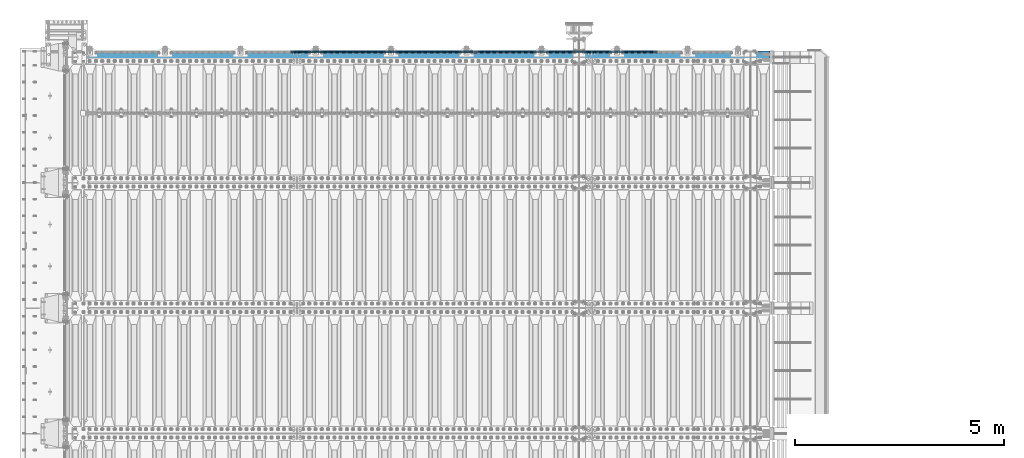
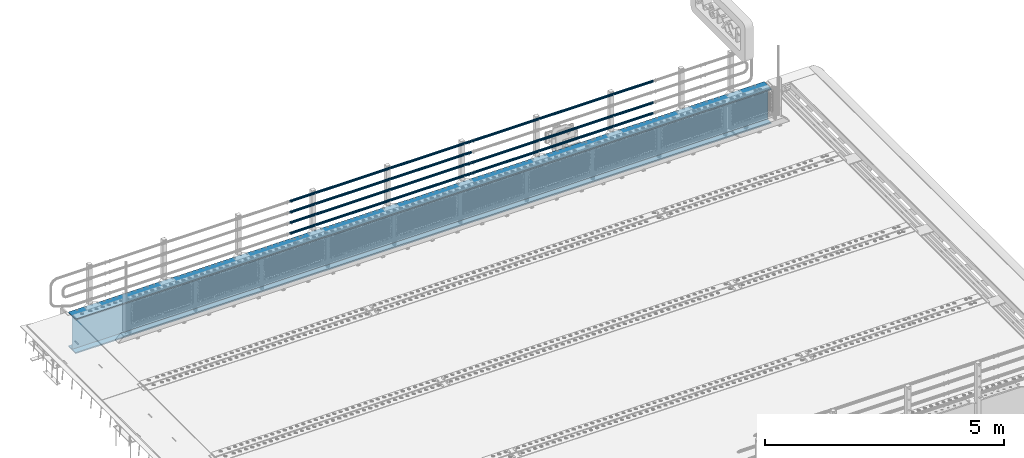
# One storey, part 128 of 257: 8 beams.
"""IFC2X3 building model written with IfcOpenShell, lengths in millimetres."""

from ifc_helpers import new_model, si_unit, frame, origin_with_axes, place, context, subcontext, project, spatial, faceted_brep, material, type_object, element, save


model = new_model("IFC2X3")

# Units and contexts
model_context = context("Model", 3, precision=1e-05, world=origin_with_axes())
body_context = subcontext(model_context, "Body", "Model", "MODEL_VIEW")
ifc_project = project(units=[si_unit("LENGTHUNIT", "METRE", prefix="MILLI"), si_unit("AREAUNIT", "SQUARE_METRE"), si_unit("VOLUMEUNIT", "CUBIC_METRE"), si_unit("MASSUNIT", "GRAM", prefix="KILO"), si_unit("TIMEUNIT", "SECOND"), si_unit("PLANEANGLEUNIT", "RADIAN"), si_unit("SOLIDANGLEUNIT", "STERADIAN"), si_unit("THERMODYNAMICTEMPERATUREUNIT", "DEGREE_CELSIUS"), si_unit("LUMINOUSINTENSITYUNIT", "LUMEN")], contexts=[model_context])

# Site, building, storey
site_placement = place(None, origin_with_axes())
site = spatial("IfcSite", under=ifc_project, at=site_placement, CompositionType="ELEMENT")
building_placement = place(site_placement, origin_with_axes())
building = spatial("IfcBuilding", under=site, at=building_placement, Name="Standard", CompositionType="ELEMENT")
storey_placement = place(building_placement, origin_with_axes())
storey = spatial("IfcBuildingStorey", under=building, at=storey_placement, Name="Undefined", CompositionType="ELEMENT", Elevation=0.0)

# Beams
ifc_material_1 = material()
beam_type_1 = type_object("IfcBeamType", PredefinedType="NOTDEFINED")
beam_1_placement = place(storey_placement, frame((52177.9999999999, 12129.8500000001, 149.849999999725), z_axis=(0.0, 0.0, -1.0), x_axis=(-1.0, 0.0, 0.0)))
element("IfcBeam", 1, at=beam_1_placement, inside=storey, type_object=beam_type_1, material=ifc_material_1, context=body_context, shape_type="Brep", body=[
    faceted_brep([(0.0, -26.5499999999993, 0.0), (0.0, -24.5290015881747, 10.1602451292931), (4384.00249699992, -24.5290015881747, 10.1602451292931), (4384.00249699992, -26.5499999999993, 0.0), (0.0, -18.7736850405036, 18.7736850405028), (4384.00249699992, -18.7736850405036, 18.7736850405028), (0.0, -10.1602451292929, 24.5290015881747), (4384.00249699992, -10.1602451292929, 24.5290015881747), (0.0, 0.0, 26.55), (4384.00249699992, 0.0, 26.55), (0.0, 10.1602451292929, 24.5290015881747), (4384.00249699992, 10.1602451292929, 24.5290015881747), (0.0, 18.7736850405036, 18.7736850405028), (4384.00249699992, 18.7736850405036, 18.7736850405028), (0.0, 24.5290015881747, 10.1602451292931), (4384.00249699992, 24.5290015881747, 10.1602451292931), (0.0, 26.5499999999993, 0.0), (4384.00249699992, 26.5499999999993, 0.0), (0.0, 24.5290015881747, -10.1602451292931), (4384.00249699992, 24.5290015881747, -10.1602451292931), (0.0, 18.7736850405036, -18.7736850405028), (4384.00249699992, 18.7736850405036, -18.7736850405028), (0.0, 10.1602451292929, -24.5290015881747), (4384.00249699992, 10.1602451292929, -24.5290015881747), (0.0, 0.0, -26.55), (4384.00249699992, 0.0, -26.55), (0.0, -10.1602451292929, -24.5290015881747), (4384.00249699992, -10.1602451292929, -24.5290015881747), (0.0, -18.7736850405036, -18.7736850405028), (4384.00249699992, -18.7736850405036, -18.7736850405028), (0.0, -24.5290015881747, -10.1602451292931), (4384.00249699992, -24.5290015881747, -10.1602451292931), (0.0, -30.1499999999996, 0.0), (0.0, -27.8549679052157, -11.5379054858058), (4384.00249699992, -27.8549679052157, -11.5379054858075), (4384.00249699992, -30.1499999999996, 0.0), (0.0, -21.3192694527752, -21.3192694527752), (4384.00249699992, -21.3192694527752, -21.3192694527744), (0.0, -11.5379054858076, -27.8549679052157), (4384.00249699992, -11.5379054858076, -27.8549679052153), (0.0, 0.0, -30.1500000000015), (4384.00249699992, 0.0, -30.15), (0.0, 11.5379054858076, -27.8549679052157), (4384.00249699992, 11.5379054858076, -27.8549679052153), (0.0, 21.3192694527752, -21.3192694527752), (4384.00249699992, 21.3192694527752, -21.3192694527744), (0.0, 27.8549679052157, -11.5379054858058), (4384.00249699992, 27.8549679052157, -11.5379054858074), (0.0, 30.1499999999996, 0.0), (4384.00249699992, 30.1499999999996, 0.0), (0.0, 27.8549679052157, 11.5379054858058), (4384.00249699992, 27.8549679052157, 11.5379054858075), (0.0, 21.3192694527752, 21.3192694527752), (4384.00249699992, 21.3192694527752, 21.3192694527744), (0.0, 11.5379054858076, 27.8549679052157), (4384.00249699992, 11.5379054858076, 27.8549679052153), (0.0, 0.0, 30.1500000000015), (4384.00249699992, 0.0, 30.15), (0.0, -11.5379054858076, 27.8549679052157), (4384.00249699992, -11.5379054858076, 27.8549679052153), (0.0, -21.3192694527752, 21.3192694527752), (4384.00249699992, -21.3192694527752, 21.3192694527744), (0.0, -27.8549679052157, 11.5379054858058), (4384.00249699992, -27.8549679052157, 11.5379054858075)], [[[0, 1, 2, 3]], [[1, 4, 5, 2]], [[4, 6, 7, 5]], [[6, 8, 9, 7]], [[8, 10, 11, 9]], [[10, 12, 13, 11]], [[12, 14, 15, 13]], [[14, 16, 17, 15]], [[16, 18, 19, 17]], [[18, 20, 21, 19]], [[20, 22, 23, 21]], [[22, 24, 25, 23]], [[24, 26, 27, 25]], [[26, 28, 29, 27]], [[28, 30, 31, 29]], [[30, 0, 3, 31]], [[32, 33, 34, 35]], [[33, 36, 37, 34]], [[36, 38, 39, 37]], [[38, 40, 41, 39]], [[40, 42, 43, 41]], [[42, 44, 45, 43]], [[44, 46, 47, 45]], [[46, 48, 49, 47]], [[48, 50, 51, 49]], [[50, 52, 53, 51]], [[52, 54, 55, 53]], [[54, 56, 57, 55]], [[56, 58, 59, 57]], [[58, 60, 61, 59]], [[60, 62, 63, 61]], [[62, 32, 35, 63]], [[37, 39, 41, 43, 45, 47, 49, 51, 53, 55, 57, 59, 61, 63, 35, 34], [5, 7, 9, 11, 13, 15, 17, 19, 21, 23, 25, 27, 29, 31, 3, 2]], [[62, 60, 58, 56, 54, 52, 50, 48, 46, 44, 42, 40, 38, 36, 33, 32], [30, 28, 26, 24, 22, 20, 18, 16, 14, 12, 10, 8, 6, 4, 1, 0]]]),
])
beam_2_placement = place(storey_placement, frame((56571.9999999999, 12129.8500000002, 149.849999999725), z_axis=(0.0, 0.0, -1.0), x_axis=(-1.0, 0.0, 0.0)))
element("IfcBeam", 2, at=beam_2_placement, inside=storey, type_object=beam_type_1, material=ifc_material_1, context=body_context, shape_type="Brep", body=[
    faceted_brep([(0.0, -26.5499999999993, 0.0), (0.0, -24.5290015881747, 10.1602451292931), (4384.0, -24.5290015881747, 10.1602451292931), (4384.0, -26.5499999999993, 0.0), (0.0, -18.7736850405036, 18.7736850405028), (4384.0, -18.7736850405036, 18.7736850405028), (0.0, -10.1602451292929, 24.5290015881747), (4384.0, -10.1602451292929, 24.5290015881747), (0.0, 0.0, 26.55), (4384.0, 0.0, 26.55), (0.0, 10.1602451292929, 24.5290015881747), (4384.0, 10.1602451292929, 24.5290015881747), (0.0, 18.7736850405036, 18.7736850405028), (4384.0, 18.7736850405036, 18.7736850405028), (0.0, 24.5290015881747, 10.1602451292931), (4384.0, 24.5290015881747, 10.1602451292931), (0.0, 26.5499999999993, 0.0), (4384.0, 26.5499999999993, 0.0), (0.0, 24.5290015881747, -10.1602451292931), (4384.0, 24.5290015881747, -10.1602451292931), (0.0, 18.7736850405036, -18.7736850405028), (4384.0, 18.7736850405036, -18.7736850405028), (0.0, 10.1602451292929, -24.5290015881747), (4384.0, 10.1602451292929, -24.5290015881747), (0.0, 0.0, -26.55), (4384.0, 0.0, -26.55), (0.0, -10.1602451292929, -24.5290015881747), (4384.0, -10.1602451292929, -24.5290015881747), (0.0, -18.7736850405036, -18.7736850405028), (4384.0, -18.7736850405036, -18.7736850405028), (0.0, -24.5290015881747, -10.1602451292931), (4384.0, -24.5290015881747, -10.1602451292931), (0.0, -30.1499999999996, 0.0), (0.0, -27.8549679052157, -11.5379054858058), (4384.0, -27.8549679052157, -11.5379054858075), (4384.0, -30.1499999999996, 0.0), (0.0, -21.3192694527752, -21.3192694527752), (4384.0, -21.3192694527752, -21.3192694527744), (0.0, -11.5379054858076, -27.8549679052157), (4384.0, -11.5379054858076, -27.8549679052153), (0.0, 0.0, -30.1500000000015), (4384.0, 0.0, -30.15), (0.0, 11.5379054858076, -27.8549679052157), (4384.0, 11.5379054858076, -27.8549679052153), (0.0, 21.3192694527752, -21.3192694527752), (4384.0, 21.3192694527752, -21.3192694527744), (0.0, 27.8549679052157, -11.5379054858058), (4384.0, 27.8549679052157, -11.5379054858074), (0.0, 30.1499999999996, 0.0), (4384.0, 30.1499999999996, 0.0), (0.0, 27.8549679052157, 11.5379054858058), (4384.0, 27.8549679052157, 11.5379054858075), (0.0, 21.3192694527752, 21.3192694527752), (4384.0, 21.3192694527752, 21.3192694527744), (0.0, 11.5379054858076, 27.8549679052157), (4384.0, 11.5379054858076, 27.8549679052153), (0.0, 0.0, 30.1500000000015), (4384.0, 0.0, 30.15), (0.0, -11.5379054858076, 27.8549679052157), (4384.0, -11.5379054858076, 27.8549679052153), (0.0, -21.3192694527752, 21.3192694527752), (4384.0, -21.3192694527752, 21.3192694527744), (0.0, -27.8549679052157, 11.5379054858058), (4384.0, -27.8549679052157, 11.5379054858075)], [[[0, 1, 2, 3]], [[1, 4, 5, 2]], [[4, 6, 7, 5]], [[6, 8, 9, 7]], [[8, 10, 11, 9]], [[10, 12, 13, 11]], [[12, 14, 15, 13]], [[14, 16, 17, 15]], [[16, 18, 19, 17]], [[18, 20, 21, 19]], [[20, 22, 23, 21]], [[22, 24, 25, 23]], [[24, 26, 27, 25]], [[26, 28, 29, 27]], [[28, 30, 31, 29]], [[30, 0, 3, 31]], [[32, 33, 34, 35]], [[33, 36, 37, 34]], [[36, 38, 39, 37]], [[38, 40, 41, 39]], [[40, 42, 43, 41]], [[42, 44, 45, 43]], [[44, 46, 47, 45]], [[46, 48, 49, 47]], [[48, 50, 51, 49]], [[50, 52, 53, 51]], [[52, 54, 55, 53]], [[54, 56, 57, 55]], [[56, 58, 59, 57]], [[58, 60, 61, 59]], [[60, 62, 63, 61]], [[62, 32, 35, 63]], [[37, 39, 41, 43, 45, 47, 49, 51, 53, 55, 57, 59, 61, 63, 35, 34], [5, 7, 9, 11, 13, 15, 17, 19, 21, 23, 25, 27, 29, 31, 3, 2]], [[62, 60, 58, 56, 54, 52, 50, 48, 46, 44, 42, 40, 38, 36, 33, 32], [30, 28, 26, 24, 22, 20, 18, 16, 14, 12, 10, 8, 6, 4, 1, 0]]]),
])
beam_3_placement = place(storey_placement, frame((52177.9999999999, 12129.8500000001, 420.149999999728), z_axis=(0.0, 0.0, -1.0), x_axis=(-1.0, 0.0, 0.0)))
element("IfcBeam", 3, at=beam_3_placement, inside=storey, type_object=beam_type_1, material=ifc_material_1, context=body_context, shape_type="Brep", body=[
    faceted_brep([(0.0, -26.5499999999993, 0.0), (0.0, -24.5290015881747, 10.1602451292931), (4384.00249699992, -24.5290015881747, 10.1602451292931), (4384.00249699992, -26.5499999999993, 0.0), (0.0, -18.7736850405036, 18.7736850405028), (4384.00249699992, -18.7736850405036, 18.7736850405028), (0.0, -10.1602451292929, 24.5290015881747), (4384.00249699992, -10.1602451292929, 24.5290015881747), (0.0, 0.0, 26.55), (4384.00249699992, 0.0, 26.55), (0.0, 10.1602451292929, 24.5290015881747), (4384.00249699992, 10.1602451292929, 24.5290015881747), (0.0, 18.7736850405036, 18.7736850405028), (4384.00249699992, 18.7736850405036, 18.7736850405028), (0.0, 24.5290015881747, 10.1602451292931), (4384.00249699992, 24.5290015881747, 10.1602451292931), (0.0, 26.5499999999993, 0.0), (4384.00249699992, 26.5499999999993, 0.0), (0.0, 24.5290015881747, -10.1602451292931), (4384.00249699992, 24.5290015881747, -10.1602451292931), (0.0, 18.7736850405036, -18.7736850405028), (4384.00249699992, 18.7736850405036, -18.7736850405028), (0.0, 10.1602451292929, -24.5290015881747), (4384.00249699992, 10.1602451292929, -24.5290015881747), (0.0, 0.0, -26.55), (4384.00249699992, 0.0, -26.55), (0.0, -10.1602451292929, -24.5290015881747), (4384.00249699992, -10.1602451292929, -24.5290015881747), (0.0, -18.7736850405036, -18.7736850405028), (4384.00249699992, -18.7736850405036, -18.7736850405028), (0.0, -24.5290015881747, -10.1602451292931), (4384.00249699992, -24.5290015881747, -10.1602451292931), (0.0, -30.1499999999996, 0.0), (0.0, -27.8549679052157, -11.5379054858058), (4384.00249699992, -27.8549679052157, -11.5379054858075), (4384.00249699992, -30.1499999999996, 0.0), (0.0, -21.3192694527752, -21.3192694527752), (4384.00249699992, -21.3192694527752, -21.3192694527744), (0.0, -11.5379054858076, -27.8549679052157), (4384.00249699992, -11.5379054858076, -27.8549679052153), (0.0, 0.0, -30.1500000000015), (4384.00249699992, 0.0, -30.15), (0.0, 11.5379054858076, -27.8549679052157), (4384.00249699992, 11.5379054858076, -27.8549679052153), (0.0, 21.3192694527752, -21.3192694527752), (4384.00249699992, 21.3192694527752, -21.3192694527744), (0.0, 27.8549679052157, -11.5379054858058), (4384.00249699992, 27.8549679052157, -11.5379054858074), (0.0, 30.1499999999996, 0.0), (4384.00249699992, 30.1499999999996, 0.0), (0.0, 27.8549679052157, 11.5379054858058), (4384.00249699992, 27.8549679052157, 11.5379054858075), (0.0, 21.3192694527752, 21.3192694527752), (4384.00249699992, 21.3192694527752, 21.3192694527744), (0.0, 11.5379054858076, 27.8549679052157), (4384.00249699992, 11.5379054858076, 27.8549679052153), (0.0, 0.0, 30.1500000000015), (4384.00249699992, 0.0, 30.15), (0.0, -11.5379054858076, 27.8549679052157), (4384.00249699992, -11.5379054858076, 27.8549679052153), (0.0, -21.3192694527752, 21.3192694527752), (4384.00249699992, -21.3192694527752, 21.3192694527744), (0.0, -27.8549679052157, 11.5379054858058), (4384.00249699992, -27.8549679052157, 11.5379054858075)], [[[0, 1, 2, 3]], [[1, 4, 5, 2]], [[4, 6, 7, 5]], [[6, 8, 9, 7]], [[8, 10, 11, 9]], [[10, 12, 13, 11]], [[12, 14, 15, 13]], [[14, 16, 17, 15]], [[16, 18, 19, 17]], [[18, 20, 21, 19]], [[20, 22, 23, 21]], [[22, 24, 25, 23]], [[24, 26, 27, 25]], [[26, 28, 29, 27]], [[28, 30, 31, 29]], [[30, 0, 3, 31]], [[32, 33, 34, 35]], [[33, 36, 37, 34]], [[36, 38, 39, 37]], [[38, 40, 41, 39]], [[40, 42, 43, 41]], [[42, 44, 45, 43]], [[44, 46, 47, 45]], [[46, 48, 49, 47]], [[48, 50, 51, 49]], [[50, 52, 53, 51]], [[52, 54, 55, 53]], [[54, 56, 57, 55]], [[56, 58, 59, 57]], [[58, 60, 61, 59]], [[60, 62, 63, 61]], [[62, 32, 35, 63]], [[37, 39, 41, 43, 45, 47, 49, 51, 53, 55, 57, 59, 61, 63, 35, 34], [5, 7, 9, 11, 13, 15, 17, 19, 21, 23, 25, 27, 29, 31, 3, 2]], [[62, 60, 58, 56, 54, 52, 50, 48, 46, 44, 42, 40, 38, 36, 33, 32], [30, 28, 26, 24, 22, 20, 18, 16, 14, 12, 10, 8, 6, 4, 1, 0]]]),
])
beam_4_placement = place(storey_placement, frame((56571.9999999999, 12129.8500000002, 420.149999999728), z_axis=(0.0, 0.0, -1.0), x_axis=(-1.0, 0.0, 0.0)))
element("IfcBeam", 4, at=beam_4_placement, inside=storey, type_object=beam_type_1, material=ifc_material_1, context=body_context, shape_type="Brep", body=[
    faceted_brep([(0.0, -26.5499999999993, 0.0), (0.0, -24.5290015881747, 10.1602451292931), (4384.0, -24.5290015881747, 10.1602451292931), (4384.0, -26.5499999999993, 0.0), (0.0, -18.7736850405036, 18.7736850405028), (4384.0, -18.7736850405036, 18.7736850405028), (0.0, -10.1602451292929, 24.5290015881747), (4384.0, -10.1602451292929, 24.5290015881747), (0.0, 0.0, 26.55), (4384.0, 0.0, 26.55), (0.0, 10.1602451292929, 24.5290015881747), (4384.0, 10.1602451292929, 24.5290015881747), (0.0, 18.7736850405036, 18.7736850405028), (4384.0, 18.7736850405036, 18.7736850405028), (0.0, 24.5290015881747, 10.1602451292931), (4384.0, 24.5290015881747, 10.1602451292931), (0.0, 26.5499999999993, 0.0), (4384.0, 26.5499999999993, 0.0), (0.0, 24.5290015881747, -10.1602451292931), (4384.0, 24.5290015881747, -10.1602451292931), (0.0, 18.7736850405036, -18.7736850405028), (4384.0, 18.7736850405036, -18.7736850405028), (0.0, 10.1602451292929, -24.5290015881747), (4384.0, 10.1602451292929, -24.5290015881747), (0.0, 0.0, -26.55), (4384.0, 0.0, -26.55), (0.0, -10.1602451292929, -24.5290015881747), (4384.0, -10.1602451292929, -24.5290015881747), (0.0, -18.7736850405036, -18.7736850405028), (4384.0, -18.7736850405036, -18.7736850405028), (0.0, -24.5290015881747, -10.1602451292931), (4384.0, -24.5290015881747, -10.1602451292931), (0.0, -30.1499999999996, 0.0), (0.0, -27.8549679052157, -11.5379054858058), (4384.0, -27.8549679052157, -11.5379054858075), (4384.0, -30.1499999999996, 0.0), (0.0, -21.3192694527752, -21.3192694527752), (4384.0, -21.3192694527752, -21.3192694527744), (0.0, -11.5379054858076, -27.8549679052157), (4384.0, -11.5379054858076, -27.8549679052153), (0.0, 0.0, -30.1500000000015), (4384.0, 0.0, -30.15), (0.0, 11.5379054858076, -27.8549679052157), (4384.0, 11.5379054858076, -27.8549679052153), (0.0, 21.3192694527752, -21.3192694527752), (4384.0, 21.3192694527752, -21.3192694527744), (0.0, 27.8549679052157, -11.5379054858058), (4384.0, 27.8549679052157, -11.5379054858074), (0.0, 30.1499999999996, 0.0), (4384.0, 30.1499999999996, 0.0), (0.0, 27.8549679052157, 11.5379054858058), (4384.0, 27.8549679052157, 11.5379054858075), (0.0, 21.3192694527752, 21.3192694527752), (4384.0, 21.3192694527752, 21.3192694527744), (0.0, 11.5379054858076, 27.8549679052157), (4384.0, 11.5379054858076, 27.8549679052153), (0.0, 0.0, 30.1500000000015), (4384.0, 0.0, 30.15), (0.0, -11.5379054858076, 27.8549679052157), (4384.0, -11.5379054858076, 27.8549679052153), (0.0, -21.3192694527752, 21.3192694527752), (4384.0, -21.3192694527752, 21.3192694527744), (0.0, -27.8549679052157, 11.5379054858058), (4384.0, -27.8549679052157, 11.5379054858075)], [[[0, 1, 2, 3]], [[1, 4, 5, 2]], [[4, 6, 7, 5]], [[6, 8, 9, 7]], [[8, 10, 11, 9]], [[10, 12, 13, 11]], [[12, 14, 15, 13]], [[14, 16, 17, 15]], [[16, 18, 19, 17]], [[18, 20, 21, 19]], [[20, 22, 23, 21]], [[22, 24, 25, 23]], [[24, 26, 27, 25]], [[26, 28, 29, 27]], [[28, 30, 31, 29]], [[30, 0, 3, 31]], [[32, 33, 34, 35]], [[33, 36, 37, 34]], [[36, 38, 39, 37]], [[38, 40, 41, 39]], [[40, 42, 43, 41]], [[42, 44, 45, 43]], [[44, 46, 47, 45]], [[46, 48, 49, 47]], [[48, 50, 51, 49]], [[50, 52, 53, 51]], [[52, 54, 55, 53]], [[54, 56, 57, 55]], [[56, 58, 59, 57]], [[58, 60, 61, 59]], [[60, 62, 63, 61]], [[62, 32, 35, 63]], [[37, 39, 41, 43, 45, 47, 49, 51, 53, 55, 57, 59, 61, 63, 35, 34], [5, 7, 9, 11, 13, 15, 17, 19, 21, 23, 25, 27, 29, 31, 3, 2]], [[62, 60, 58, 56, 54, 52, 50, 48, 46, 44, 42, 40, 38, 36, 33, 32], [30, 28, 26, 24, 22, 20, 18, 16, 14, 12, 10, 8, 6, 4, 1, 0]]]),
])
beam_5_placement = place(storey_placement, frame((52177.9999999999, 12129.8500000001, 969.849999999725), z_axis=(0.0, 0.0, -1.0), x_axis=(-1.0, 0.0, 0.0)))
element("IfcBeam", 5, at=beam_5_placement, inside=storey, type_object=beam_type_1, material=ifc_material_1, context=body_context, shape_type="Brep", body=[
    faceted_brep([(0.0, -26.5499999999993, 0.0), (0.0, -24.5290015881747, 10.1602451292931), (4384.00249699992, -24.5290015881747, 10.1602451292931), (4384.00249699992, -26.5499999999993, 0.0), (0.0, -18.7736850405036, 18.7736850405028), (4384.00249699992, -18.7736850405036, 18.7736850405028), (0.0, -10.1602451292929, 24.5290015881747), (4384.00249699992, -10.1602451292929, 24.5290015881747), (0.0, 0.0, 26.55), (4384.00249699992, 0.0, 26.55), (0.0, 10.1602451292929, 24.5290015881747), (4384.00249699992, 10.1602451292929, 24.5290015881747), (0.0, 18.7736850405036, 18.7736850405028), (4384.00249699992, 18.7736850405036, 18.7736850405028), (0.0, 24.5290015881747, 10.1602451292931), (4384.00249699992, 24.5290015881747, 10.1602451292931), (0.0, 26.5499999999993, 0.0), (4384.00249699992, 26.5499999999993, 0.0), (0.0, 24.5290015881747, -10.1602451292931), (4384.00249699992, 24.5290015881747, -10.1602451292931), (0.0, 18.7736850405036, -18.7736850405028), (4384.00249699992, 18.7736850405036, -18.7736850405028), (0.0, 10.1602451292929, -24.5290015881747), (4384.00249699992, 10.1602451292929, -24.5290015881747), (0.0, 0.0, -26.55), (4384.00249699992, 0.0, -26.55), (0.0, -10.1602451292929, -24.5290015881747), (4384.00249699992, -10.1602451292929, -24.5290015881747), (0.0, -18.7736850405036, -18.7736850405028), (4384.00249699992, -18.7736850405036, -18.7736850405028), (0.0, -24.5290015881747, -10.1602451292931), (4384.00249699992, -24.5290015881747, -10.1602451292931), (0.0, -30.1499999999996, 0.0), (0.0, -27.8549679052157, -11.5379054858058), (4384.00249699992, -27.8549679052157, -11.5379054858075), (4384.00249699992, -30.1499999999996, 0.0), (0.0, -21.3192694527752, -21.3192694527752), (4384.00249699992, -21.3192694527752, -21.3192694527744), (0.0, -11.5379054858076, -27.8549679052157), (4384.00249699992, -11.5379054858076, -27.8549679052153), (0.0, 0.0, -30.1500000000015), (4384.00249699992, 0.0, -30.15), (0.0, 11.5379054858076, -27.8549679052157), (4384.00249699992, 11.5379054858076, -27.8549679052153), (0.0, 21.3192694527752, -21.3192694527752), (4384.00249699992, 21.3192694527752, -21.3192694527744), (0.0, 27.8549679052157, -11.5379054858058), (4384.00249699992, 27.8549679052157, -11.5379054858074), (0.0, 30.1499999999996, 0.0), (4384.00249699992, 30.1499999999996, 0.0), (0.0, 27.8549679052157, 11.5379054858058), (4384.00249699992, 27.8549679052157, 11.5379054858075), (0.0, 21.3192694527752, 21.3192694527752), (4384.00249699992, 21.3192694527752, 21.3192694527744), (0.0, 11.5379054858076, 27.8549679052157), (4384.00249699992, 11.5379054858076, 27.8549679052153), (0.0, 0.0, 30.1500000000015), (4384.00249699992, 0.0, 30.15), (0.0, -11.5379054858076, 27.8549679052157), (4384.00249699992, -11.5379054858076, 27.8549679052153), (0.0, -21.3192694527752, 21.3192694527752), (4384.00249699992, -21.3192694527752, 21.3192694527744), (0.0, -27.8549679052157, 11.5379054858058), (4384.00249699992, -27.8549679052157, 11.5379054858075)], [[[0, 1, 2, 3]], [[1, 4, 5, 2]], [[4, 6, 7, 5]], [[6, 8, 9, 7]], [[8, 10, 11, 9]], [[10, 12, 13, 11]], [[12, 14, 15, 13]], [[14, 16, 17, 15]], [[16, 18, 19, 17]], [[18, 20, 21, 19]], [[20, 22, 23, 21]], [[22, 24, 25, 23]], [[24, 26, 27, 25]], [[26, 28, 29, 27]], [[28, 30, 31, 29]], [[30, 0, 3, 31]], [[32, 33, 34, 35]], [[33, 36, 37, 34]], [[36, 38, 39, 37]], [[38, 40, 41, 39]], [[40, 42, 43, 41]], [[42, 44, 45, 43]], [[44, 46, 47, 45]], [[46, 48, 49, 47]], [[48, 50, 51, 49]], [[50, 52, 53, 51]], [[52, 54, 55, 53]], [[54, 56, 57, 55]], [[56, 58, 59, 57]], [[58, 60, 61, 59]], [[60, 62, 63, 61]], [[62, 32, 35, 63]], [[37, 39, 41, 43, 45, 47, 49, 51, 53, 55, 57, 59, 61, 63, 35, 34], [5, 7, 9, 11, 13, 15, 17, 19, 21, 23, 25, 27, 29, 31, 3, 2]], [[62, 60, 58, 56, 54, 52, 50, 48, 46, 44, 42, 40, 38, 36, 33, 32], [30, 28, 26, 24, 22, 20, 18, 16, 14, 12, 10, 8, 6, 4, 1, 0]]]),
])
beam_6_placement = place(storey_placement, frame((56571.9999999999, 12129.8500000002, 969.849999999725), z_axis=(0.0, 0.0, -1.0), x_axis=(-1.0, 0.0, 0.0)))
element("IfcBeam", 6, at=beam_6_placement, inside=storey, type_object=beam_type_1, material=ifc_material_1, context=body_context, shape_type="Brep", body=[
    faceted_brep([(0.0, -26.5499999999993, 0.0), (0.0, -24.5290015881747, 10.1602451292931), (4384.0, -24.5290015881747, 10.1602451292931), (4384.0, -26.5499999999993, 0.0), (0.0, -18.7736850405036, 18.7736850405028), (4384.0, -18.7736850405036, 18.7736850405028), (0.0, -10.1602451292929, 24.5290015881747), (4384.0, -10.1602451292929, 24.5290015881747), (0.0, 0.0, 26.55), (4384.0, 0.0, 26.55), (0.0, 10.1602451292929, 24.5290015881747), (4384.0, 10.1602451292929, 24.5290015881747), (0.0, 18.7736850405036, 18.7736850405028), (4384.0, 18.7736850405036, 18.7736850405028), (0.0, 24.5290015881747, 10.1602451292931), (4384.0, 24.5290015881747, 10.1602451292931), (0.0, 26.5499999999993, 0.0), (4384.0, 26.5499999999993, 0.0), (0.0, 24.5290015881747, -10.1602451292931), (4384.0, 24.5290015881747, -10.1602451292931), (0.0, 18.7736850405036, -18.7736850405028), (4384.0, 18.7736850405036, -18.7736850405028), (0.0, 10.1602451292929, -24.5290015881747), (4384.0, 10.1602451292929, -24.5290015881747), (0.0, 0.0, -26.55), (4384.0, 0.0, -26.55), (0.0, -10.1602451292929, -24.5290015881747), (4384.0, -10.1602451292929, -24.5290015881747), (0.0, -18.7736850405036, -18.7736850405028), (4384.0, -18.7736850405036, -18.7736850405028), (0.0, -24.5290015881747, -10.1602451292931), (4384.0, -24.5290015881747, -10.1602451292931), (0.0, -30.1499999999996, 0.0), (0.0, -27.8549679052157, -11.5379054858058), (4384.0, -27.8549679052157, -11.5379054858075), (4384.0, -30.1499999999996, 0.0), (0.0, -21.3192694527752, -21.3192694527752), (4384.0, -21.3192694527752, -21.3192694527744), (0.0, -11.5379054858076, -27.8549679052157), (4384.0, -11.5379054858076, -27.8549679052153), (0.0, 0.0, -30.1500000000015), (4384.0, 0.0, -30.15), (0.0, 11.5379054858076, -27.8549679052157), (4384.0, 11.5379054858076, -27.8549679052153), (0.0, 21.3192694527752, -21.3192694527752), (4384.0, 21.3192694527752, -21.3192694527744), (0.0, 27.8549679052157, -11.5379054858058), (4384.0, 27.8549679052157, -11.5379054858074), (0.0, 30.1499999999996, 0.0), (4384.0, 30.1499999999996, 0.0), (0.0, 27.8549679052157, 11.5379054858058), (4384.0, 27.8549679052157, 11.5379054858075), (0.0, 21.3192694527752, 21.3192694527752), (4384.0, 21.3192694527752, 21.3192694527744), (0.0, 11.5379054858076, 27.8549679052157), (4384.0, 11.5379054858076, 27.8549679052153), (0.0, 0.0, 30.1500000000015), (4384.0, 0.0, 30.15), (0.0, -11.5379054858076, 27.8549679052157), (4384.0, -11.5379054858076, 27.8549679052153), (0.0, -21.3192694527752, 21.3192694527752), (4384.0, -21.3192694527752, 21.3192694527744), (0.0, -27.8549679052157, 11.5379054858058), (4384.0, -27.8549679052157, 11.5379054858075)], [[[0, 1, 2, 3]], [[1, 4, 5, 2]], [[4, 6, 7, 5]], [[6, 8, 9, 7]], [[8, 10, 11, 9]], [[10, 12, 13, 11]], [[12, 14, 15, 13]], [[14, 16, 17, 15]], [[16, 18, 19, 17]], [[18, 20, 21, 19]], [[20, 22, 23, 21]], [[22, 24, 25, 23]], [[24, 26, 27, 25]], [[26, 28, 29, 27]], [[28, 30, 31, 29]], [[30, 0, 3, 31]], [[32, 33, 34, 35]], [[33, 36, 37, 34]], [[36, 38, 39, 37]], [[38, 40, 41, 39]], [[40, 42, 43, 41]], [[42, 44, 45, 43]], [[44, 46, 47, 45]], [[46, 48, 49, 47]], [[48, 50, 51, 49]], [[50, 52, 53, 51]], [[52, 54, 55, 53]], [[54, 56, 57, 55]], [[56, 58, 59, 57]], [[58, 60, 61, 59]], [[60, 62, 63, 61]], [[62, 32, 35, 63]], [[37, 39, 41, 43, 45, 47, 49, 51, 53, 55, 57, 59, 61, 63, 35, 34], [5, 7, 9, 11, 13, 15, 17, 19, 21, 23, 25, 27, 29, 31, 3, 2]], [[62, 60, 58, 56, 54, 52, 50, 48, 46, 44, 42, 40, 38, 36, 33, 32], [30, 28, 26, 24, 22, 20, 18, 16, 14, 12, 10, 8, 6, 4, 1, 0]]]),
])
beam_7_placement = place(storey_placement, frame((52177.9999999999, 12129.8500000001, 689.849999999725), z_axis=(0.0, 0.0, -1.0), x_axis=(-1.0, 0.0, 0.0)))
element("IfcBeam", 7, at=beam_7_placement, inside=storey, type_object=beam_type_1, material=ifc_material_1, context=body_context, shape_type="Brep", body=[
    faceted_brep([(0.0, -26.5499999999993, 0.0), (0.0, -24.5290015881747, 10.1602451292931), (4384.00249699992, -24.5290015881747, 10.1602451292931), (4384.00249699992, -26.5499999999993, 0.0), (0.0, -18.7736850405036, 18.7736850405028), (4384.00249699992, -18.7736850405036, 18.7736850405028), (0.0, -10.1602451292929, 24.5290015881747), (4384.00249699992, -10.1602451292929, 24.5290015881747), (0.0, 0.0, 26.55), (4384.00249699992, 0.0, 26.55), (0.0, 10.1602451292929, 24.5290015881747), (4384.00249699992, 10.1602451292929, 24.5290015881747), (0.0, 18.7736850405036, 18.7736850405028), (4384.00249699992, 18.7736850405036, 18.7736850405028), (0.0, 24.5290015881747, 10.1602451292931), (4384.00249699992, 24.5290015881747, 10.1602451292931), (0.0, 26.5499999999993, 0.0), (4384.00249699992, 26.5499999999993, 0.0), (0.0, 24.5290015881747, -10.1602451292931), (4384.00249699992, 24.5290015881747, -10.1602451292931), (0.0, 18.7736850405036, -18.7736850405028), (4384.00249699992, 18.7736850405036, -18.7736850405028), (0.0, 10.1602451292929, -24.5290015881747), (4384.00249699992, 10.1602451292929, -24.5290015881747), (0.0, 0.0, -26.55), (4384.00249699992, 0.0, -26.55), (0.0, -10.1602451292929, -24.5290015881747), (4384.00249699992, -10.1602451292929, -24.5290015881747), (0.0, -18.7736850405036, -18.7736850405028), (4384.00249699992, -18.7736850405036, -18.7736850405028), (0.0, -24.5290015881747, -10.1602451292931), (4384.00249699992, -24.5290015881747, -10.1602451292931), (0.0, -30.1499999999996, 0.0), (0.0, -27.8549679052157, -11.5379054858058), (4384.00249699992, -27.8549679052157, -11.5379054858075), (4384.00249699992, -30.1499999999996, 0.0), (0.0, -21.3192694527752, -21.3192694527752), (4384.00249699992, -21.3192694527752, -21.3192694527744), (0.0, -11.5379054858076, -27.8549679052157), (4384.00249699992, -11.5379054858076, -27.8549679052153), (0.0, 0.0, -30.1500000000015), (4384.00249699992, 0.0, -30.15), (0.0, 11.5379054858076, -27.8549679052157), (4384.00249699992, 11.5379054858076, -27.8549679052153), (0.0, 21.3192694527752, -21.3192694527752), (4384.00249699992, 21.3192694527752, -21.3192694527744), (0.0, 27.8549679052157, -11.5379054858058), (4384.00249699992, 27.8549679052157, -11.5379054858074), (0.0, 30.1499999999996, 0.0), (4384.00249699992, 30.1499999999996, 0.0), (0.0, 27.8549679052157, 11.5379054858058), (4384.00249699992, 27.8549679052157, 11.5379054858075), (0.0, 21.3192694527752, 21.3192694527752), (4384.00249699992, 21.3192694527752, 21.3192694527744), (0.0, 11.5379054858076, 27.8549679052157), (4384.00249699992, 11.5379054858076, 27.8549679052153), (0.0, 0.0, 30.1500000000015), (4384.00249699992, 0.0, 30.15), (0.0, -11.5379054858076, 27.8549679052157), (4384.00249699992, -11.5379054858076, 27.8549679052153), (0.0, -21.3192694527752, 21.3192694527752), (4384.00249699992, -21.3192694527752, 21.3192694527744), (0.0, -27.8549679052157, 11.5379054858058), (4384.00249699992, -27.8549679052157, 11.5379054858075)], [[[0, 1, 2, 3]], [[1, 4, 5, 2]], [[4, 6, 7, 5]], [[6, 8, 9, 7]], [[8, 10, 11, 9]], [[10, 12, 13, 11]], [[12, 14, 15, 13]], [[14, 16, 17, 15]], [[16, 18, 19, 17]], [[18, 20, 21, 19]], [[20, 22, 23, 21]], [[22, 24, 25, 23]], [[24, 26, 27, 25]], [[26, 28, 29, 27]], [[28, 30, 31, 29]], [[30, 0, 3, 31]], [[32, 33, 34, 35]], [[33, 36, 37, 34]], [[36, 38, 39, 37]], [[38, 40, 41, 39]], [[40, 42, 43, 41]], [[42, 44, 45, 43]], [[44, 46, 47, 45]], [[46, 48, 49, 47]], [[48, 50, 51, 49]], [[50, 52, 53, 51]], [[52, 54, 55, 53]], [[54, 56, 57, 55]], [[56, 58, 59, 57]], [[58, 60, 61, 59]], [[60, 62, 63, 61]], [[62, 32, 35, 63]], [[37, 39, 41, 43, 45, 47, 49, 51, 53, 55, 57, 59, 61, 63, 35, 34], [5, 7, 9, 11, 13, 15, 17, 19, 21, 23, 25, 27, 29, 31, 3, 2]], [[62, 60, 58, 56, 54, 52, 50, 48, 46, 44, 42, 40, 38, 36, 33, 32], [30, 28, 26, 24, 22, 20, 18, 16, 14, 12, 10, 8, 6, 4, 1, 0]]]),
])
ifc_material_2 = material(Name="STEEL/S355N")
beam_type_2 = type_object("IfcBeamType", Name="HEA900", PredefinedType="NOTDEFINED")
beam_8_placement = place(storey_placement, frame((42460.0, 12000.0, -445.0), z_axis=(0.0, 0.0, 1.0), x_axis=(1.0, 0.0, 0.0)))
element("IfcBeam", 8, at=beam_8_placement, inside=storey, type_object=beam_type_2, material=ifc_material_2, ObjectType="HEA900", context=body_context, shape_type="Brep", body=[
    faceted_brep([(0.0, 150.0, -445.0), (0.0, 150.0, -415.0), (16807.0, 150.0, -415.0), (16807.0, 150.0, -445.0), (0.0, 8.0, -415.0), (16807.0, 8.0, -415.0), (0.0, 8.0, 415.0), (16807.0, 8.0, 415.0), (0.0, 150.0, 415.0), (16807.0, 150.0, 415.0), (0.0, 150.0, 445.0), (16807.0, 150.0, 445.0), (0.0, -150.0, 445.0), (16807.0, -150.0, 445.0), (0.0, -150.0, 415.0), (16807.0, -150.0, 415.0), (0.0, -8.0, 415.0), (16807.0, -8.0, 415.0), (0.0, -8.0, -415.0), (16807.0, -8.0, -415.0), (0.0, -150.0, -415.0), (16807.0, -150.0, -415.0), (0.0, -150.0, -445.0), (16807.0, -150.0, -445.0)], [[[0, 1, 2, 3]], [[1, 4, 5, 2]], [[4, 6, 7, 5]], [[6, 8, 9, 7]], [[8, 10, 11, 9]], [[10, 12, 13, 11]], [[12, 14, 15, 13]], [[14, 16, 17, 15]], [[16, 18, 19, 17]], [[18, 20, 21, 19]], [[20, 22, 23, 21]], [[22, 0, 3, 23]], [[5, 7, 9, 11, 13, 15, 17, 19, 21, 23, 3, 2]], [[22, 20, 18, 16, 14, 12, 10, 8, 6, 4, 1, 0]]]),
])

save(model, "model.ifc")
